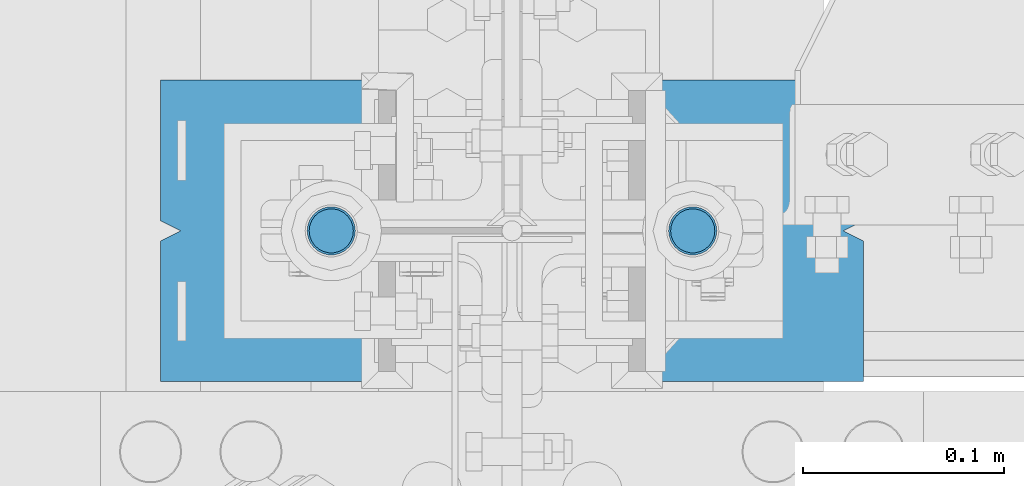
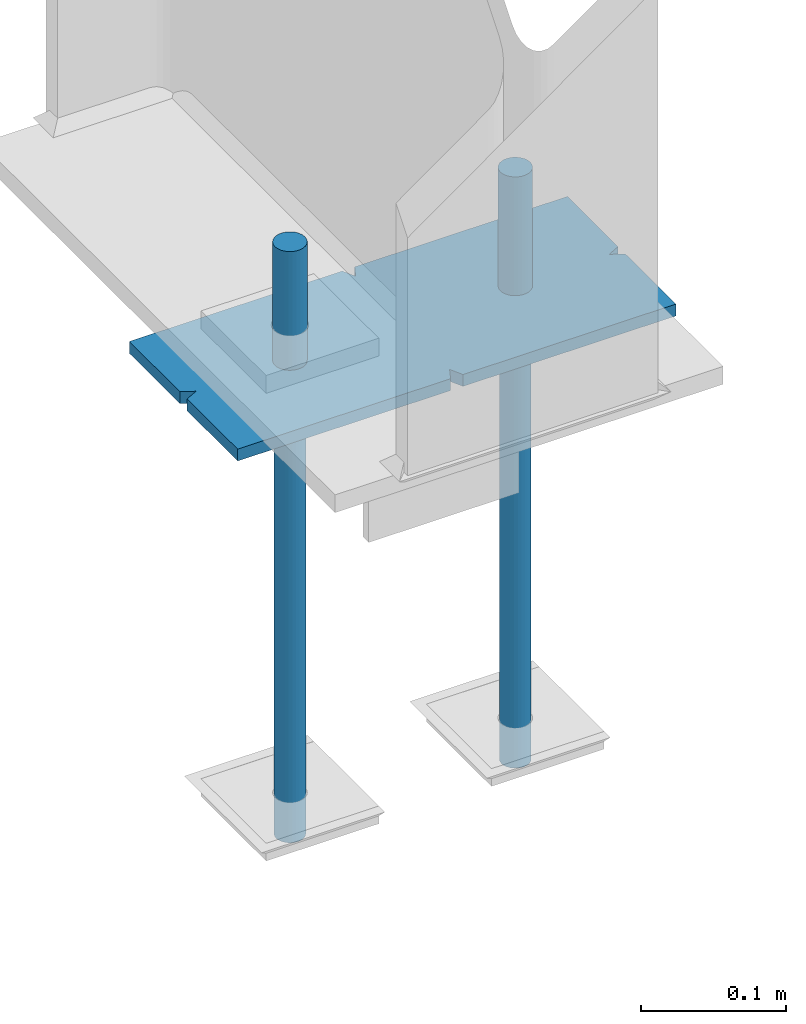
# One storey, part 103 of 496: 5 beams, 1 element without a shape of its own.
"""IFC2X3 building model written with IfcOpenShell, lengths in millimetres."""

from ifc_helpers import new_model, si_unit, frame, origin_with_axes, origin_2d_with_axis, place, context, subcontext, project, spatial, polyline, rectangle, circle, outline, extrude, boolean, material, type_object, element, aggregate, save


model = new_model("IFC2X3")

# Units and contexts
model_context = context("Model", 3, precision=1e-05, world=origin_with_axes())
body_context = subcontext(model_context, "Body", "Model", "MODEL_VIEW")
ifc_project = project(units=[si_unit("LENGTHUNIT", "METRE", prefix="MILLI"), si_unit("AREAUNIT", "SQUARE_METRE"), si_unit("VOLUMEUNIT", "CUBIC_METRE"), si_unit("MASSUNIT", "GRAM", prefix="KILO"), si_unit("TIMEUNIT", "SECOND"), si_unit("PLANEANGLEUNIT", "RADIAN"), si_unit("SOLIDANGLEUNIT", "STERADIAN"), si_unit("THERMODYNAMICTEMPERATUREUNIT", "DEGREE_CELSIUS"), si_unit("LUMINOUSINTENSITYUNIT", "LUMEN")], contexts=[model_context])

# Site, building, storey
site_placement = place(None, origin_with_axes())
site = spatial("IfcSite", under=ifc_project, at=site_placement, CompositionType="ELEMENT")
building_placement = place(site_placement, origin_with_axes())
building = spatial("IfcBuilding", under=site, at=building_placement, Name="Undefined", CompositionType="ELEMENT")
storey_placement = place(building_placement, origin_with_axes())
storey = spatial("IfcBuildingStorey", under=building, at=storey_placement, Name="Undefined", CompositionType="ELEMENT", Elevation=0.0)

# Assembly, beams
assembly_placement = place(storey_placement, origin_with_axes())
assembly = element("IfcElementAssembly", 1, at=assembly_placement, inside=storey, Name="PS24", AssemblyPlace="NOTDEFINED", PredefinedType="NOTDEFINED")
ifc_material = material(Name="Undefined/S235-E24")
beam_type_1 = type_object("IfcBeamType", Name="D24", PredefinedType="NOTDEFINED")
beam_1_placement = place(assembly_placement, frame((34189.9971504447, 0.0, -100.0), z_axis=(0.0, 1.0, 0.0), x_axis=(0.0, 0.0, -1.0)))
beam_1 = element("IfcBeam", 2, at=beam_1_placement, type_object=beam_type_1, material=ifc_material, ObjectType="D24", context=body_context, shape_type="SweptSolid", body=[
    extrude(circle(Radius=12.0, at=origin_2d_with_axis()), frame((149.999995982835, 4.54747350886464e-12, 3.63797880709171e-12), z_axis=(-1.0, 0.0, 0.0), x_axis=(0.0, -1.0, 0.0)), (0.0, 0.0, 1.0), 150.0),
])
beam_2_placement = place(assembly_placement, frame((34369.9971504447, 0.0, -100.0), z_axis=(0.0, 1.0, 0.0), x_axis=(0.0, 0.0, -1.0)))
beam_2 = element("IfcBeam", 3, at=beam_2_placement, type_object=beam_type_1, material=ifc_material, ObjectType="D24", context=body_context, shape_type="SweptSolid", body=[
    extrude(circle(Radius=12.0, at=origin_2d_with_axis()), frame((149.999995982835, 4.54747350886464e-12, 3.63797880709171e-12), z_axis=(-1.0, 0.0, 0.0), x_axis=(0.0, -1.0, 0.0)), (0.0, 0.0, 1.0), 150.0),
])
beam_type_2 = type_object("IfcBeamType", Name="D22", PredefinedType="NOTDEFINED")
beam_3_placement = place(assembly_placement, frame((34189.9971504447, 0.0, -250.0), z_axis=(0.0, 1.0, 0.0), x_axis=(0.0, 0.0, -1.0)))
beam_3 = element("IfcBeam", 4, at=beam_3_placement, type_object=beam_type_2, material=ifc_material, ObjectType="D22", context=body_context, shape_type="SweptSolid", body=[
    extrude(circle(Radius=11.0, at=origin_2d_with_axis()), frame((350.0, 0.0, 0.0), z_axis=(-1.0, 0.0, 0.0), x_axis=(0.0, -1.0, 0.0)), (0.0, 0.0, 1.0), 350.0),
])
beam_4_placement = place(assembly_placement, frame((34369.9971504447, 0.0, -250.0), z_axis=(0.0, 1.0, 0.0), x_axis=(0.0, 0.0, -1.0)))
beam_4 = element("IfcBeam", 5, at=beam_4_placement, type_object=beam_type_2, material=ifc_material, ObjectType="D22", context=body_context, shape_type="SweptSolid", body=[
    extrude(circle(Radius=11.0, at=origin_2d_with_axis()), frame((350.0, 0.0, 0.0), z_axis=(-1.0, 0.0, 0.0), x_axis=(0.0, -1.0, 0.0)), (0.0, 0.0, 1.0), 350.0),
])
beam_type_3 = type_object("IfcBeamType", PredefinedType="NOTDEFINED")
beam_5_placement = place(assembly_placement, frame((34455.0, 0.0, -205.0), z_axis=(0.0, -1.0, 0.0), x_axis=(-1.0, 0.0, 0.0)))
beam_5 = element("IfcBeam", 6, at=beam_5_placement, type_object=beam_type_3, material=ifc_material, Name="PS24", context=body_context, shape_type="CSG", body=[
    boolean("DIFFERENCE", boolean("DIFFERENCE", boolean("DIFFERENCE", boolean("DIFFERENCE", extrude(rectangle(XDim=10.0, YDim=150.0, at=origin_2d_with_axis()), frame((350.0, 0.0, 0.0), z_axis=(-1.0, 0.0, 0.0), x_axis=(0.0, -1.0, 0.0)), (0.0, 0.0, 1.0), 350.0), extrude(outline(polyline([(0.0, 0.0), (11.1803398132297, 1.2732925824821e-11), (4.47213602066586, 8.94427204135718), (0.0, 0.0)])), frame((0.0, 7.5, -5.0), z_axis=(0.0, -1.0, 0.0), x_axis=(0.894427191199935, 0.0, 0.44721359509992)), (0.0, 0.0, 1.0), 15.0)), extrude(outline(polyline([(0.0, 0.0), (11.1803398132297, 1.2732925824821e-11), (4.47213602066586, 8.94427204135718), (0.0, 0.0)])), frame((180.0, 7.5, -75.0), z_axis=(0.0, -1.0, 0.0), x_axis=(-0.447213595099959, 0.0, 0.894427191199915)), (0.0, 0.0, 1.0), 15.0)), extrude(outline(polyline([(0.0, 0.0), (11.1803398132297, 1.2732925824821e-11), (6.70820379256475, 8.94427204134627), (0.0, 0.0)])), frame((340.0, 7.5, 0.0), z_axis=(0.0, -1.0, 0.0), x_axis=(0.894427191199935, 0.0, -0.44721359509992)), (0.0, 0.0, 1.0), 15.0)), extrude(outline(polyline([(0.0, 0.0), (11.1803398132297, 1.2732925824821e-11), (4.47213602066586, 8.94427204135718), (0.0, 0.0)])), frame((170.0, 7.5, 75.0), z_axis=(0.0, -1.0, 0.0), x_axis=(0.447213595099959, 0.0, -0.894427191199915)), (0.0, 0.0, 1.0), 15.0)),
])
aggregate(assembly, [beam_1, beam_3, beam_2, beam_4, beam_5])

save(model, "model.ifc")
